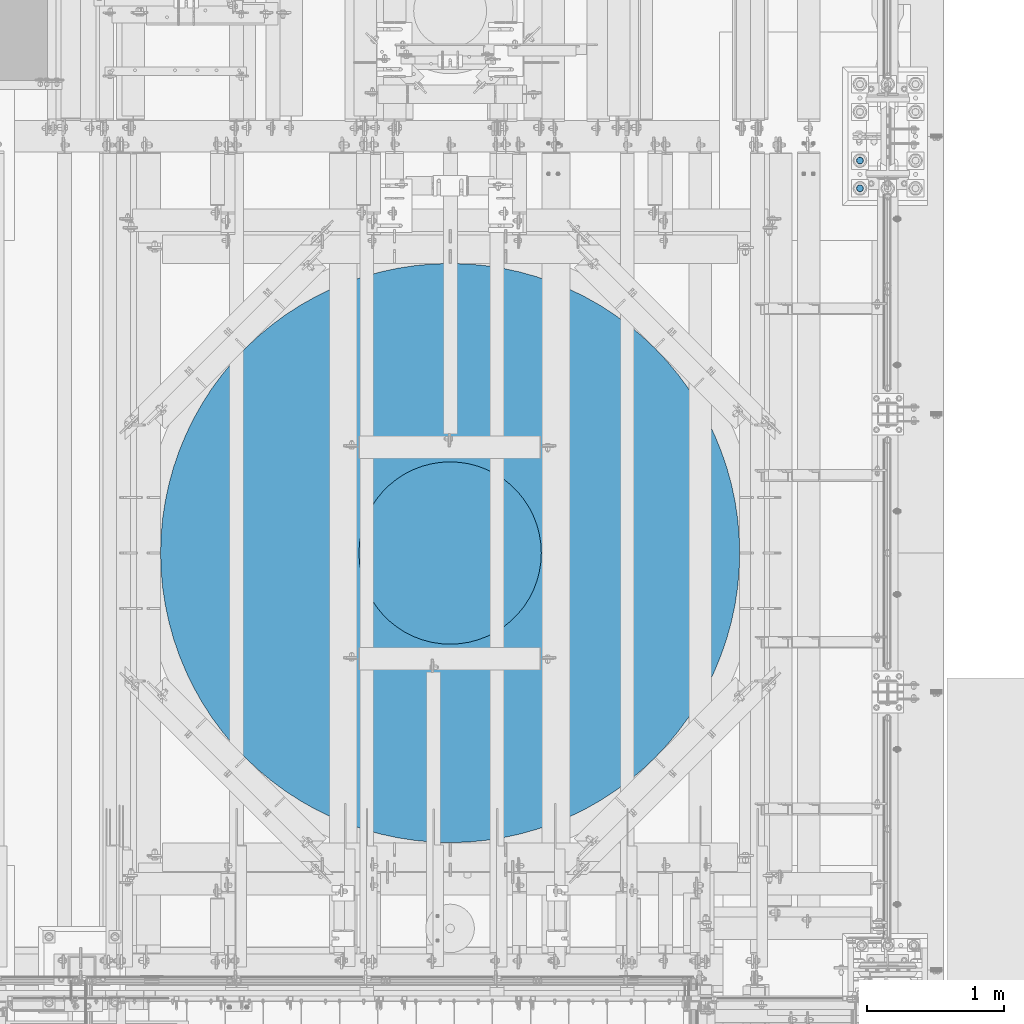
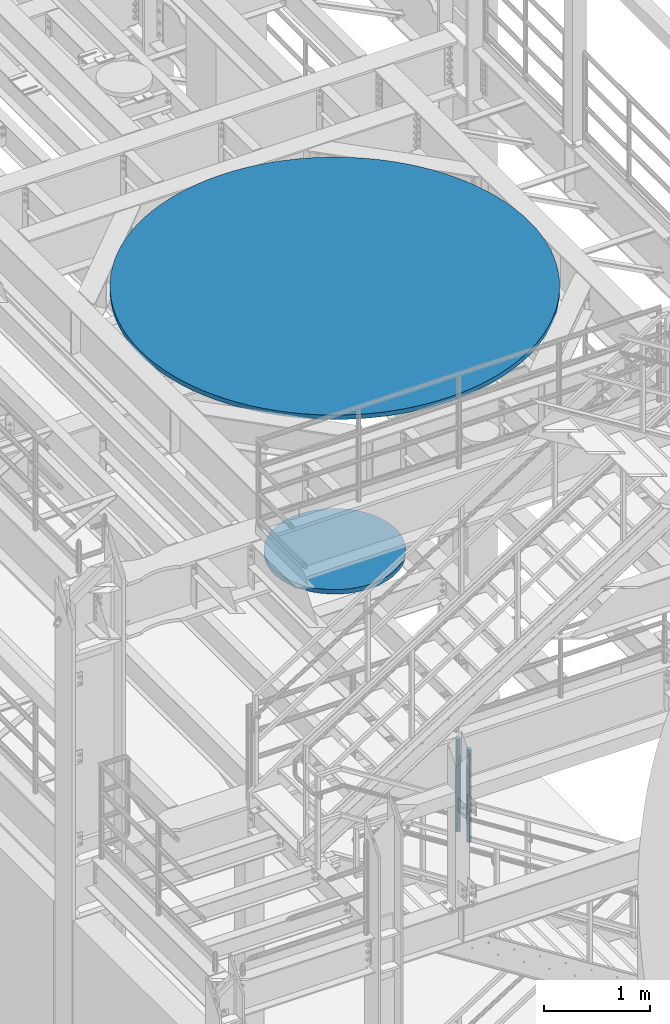
# One storey, part 690 of 1876: 4 columns, 3 elements without a shape of their own.
"""IFC2X3 building model written with IfcOpenShell, lengths in millimetres."""

from ifc_helpers import new_model, si_unit, frame, origin_with_axes, place, context, subcontext, project, spatial, faceted_brep, material, type_object, element, aggregate, save


model = new_model("IFC2X3")

# Units and contexts
model_context = context("Model", 3, precision=1e-05, world=origin_with_axes())
body_context = subcontext(model_context, "Body", "Model", "MODEL_VIEW")
ifc_project = project(units=[si_unit("LENGTHUNIT", "METRE", prefix="MILLI"), si_unit("AREAUNIT", "SQUARE_METRE"), si_unit("VOLUMEUNIT", "CUBIC_METRE"), si_unit("MASSUNIT", "GRAM", prefix="KILO"), si_unit("TIMEUNIT", "SECOND"), si_unit("PLANEANGLEUNIT", "RADIAN"), si_unit("SOLIDANGLEUNIT", "STERADIAN"), si_unit("THERMODYNAMICTEMPERATUREUNIT", "DEGREE_CELSIUS"), si_unit("LUMINOUSINTENSITYUNIT", "LUMEN")], contexts=[model_context])

# Site, building, storey
site_placement = place(None, origin_with_axes())
site = spatial("IfcSite", under=ifc_project, at=site_placement, CompositionType="ELEMENT")
building_placement = place(site_placement, origin_with_axes())
building = spatial("IfcBuilding", under=site, at=building_placement, Name="Undefined", CompositionType="ELEMENT")
storey_placement = place(building_placement, origin_with_axes())
storey = spatial("IfcBuildingStorey", under=building, at=storey_placement, Name="Undefined", CompositionType="ELEMENT", Elevation=0.0)

# Assembly, column
assembly_1_placement = place(storey_placement, origin_with_axes())
assembly_1 = element("IfcElementAssembly", 1, at=assembly_1_placement, inside=storey, Name="COLUMN", AssemblyPlace="NOTDEFINED", PredefinedType="REINFORCEMENT_UNIT")
ifc_material_1 = material(Name="CONCRETE/3000")
column_type_1 = type_object("IfcColumnType", PredefinedType="NOTDEFINED")
column_1_placement = place(assembly_1_placement, frame((4419.6, -1524.0, 8128.0), z_axis=(-1.0, 0.0, 0.0), x_axis=(0.0, 0.0, 1.0)))
column_1 = element("IfcColumn", 2, at=column_1_placement, type_object=column_type_1, material=ifc_material_1, Name="COLUMN", context=body_context, shape_type="Brep", body=[
    faceted_brep([(0.0, -2117.725, 0.0), (0.0, -2113.86132556757, -127.865053453613), (50.7999999999993, -2113.86132556757, -127.865053453613), (50.7999999999993, -2117.725, 0.0), (0.0, -2102.2844003993, -255.263541193705), (50.7999999999993, -2102.2844003993, -255.263541193705), (0.0, -2083.03646743964, -381.730599954454), (50.7999999999993, -2083.03646743964, -381.730599954454), (0.0, -2056.18776030859, -506.80476515337), (50.7999999999993, -2056.18776030859, -506.80476515337), (0.0, -2021.83624702681, -630.029654725511), (50.7999999999993, -2021.83624702681, -630.029654725511), (0.0, -1980.10727254097, -750.955634412155), (50.7999999999993, -1980.10727254097, -750.955634412155), (0.0, -1931.1531013536, -869.14145842744), (50.7999999999993, -1931.1531013536, -869.14145842744), (0.0, -1875.15236192644, -984.155879516391), (50.7999999999993, -1875.15236192644, -984.155879516391), (0.0, -1812.30939488458, -1095.57922252938), (50.7999999999993, -1812.30939488458, -1095.57922252938), (0.0, -1742.85350739964, -1203.00491577124), (50.7999999999993, -1742.85350739964, -1203.00491577124), (0.0, -1667.0381364728, -1306.04097453728), (50.7999999999993, -1667.0381364728, -1306.04097453728), (0.0, -1585.13992417064, -1404.31143142299), (50.7999999999993, -1585.13992417064, -1404.31143142299), (0.0, -1497.45770818828, -1497.45770818828), (50.7999999999993, -1497.45770818828, -1497.45770818828), (0.0, -1404.31143142299, -1585.13992417065), (50.7999999999993, -1404.31143142299, -1585.13992417065), (0.0, -1306.04097453728, -1667.0381364728), (50.7999999999993, -1306.04097453728, -1667.0381364728), (0.0, -1203.00491577124, -1742.85350739964), (50.7999999999993, -1203.00491577124, -1742.85350739964), (0.0, -1095.57922252938, -1812.30939488458), (50.7999999999993, -1095.57922252938, -1812.30939488458), (0.0, -984.155879516389, -1875.15236192644), (50.7999999999993, -984.155879516389, -1875.15236192644), (0.0, -869.141458427439, -1931.1531013536), (50.7999999999993, -869.141458427439, -1931.1531013536), (0.0, -750.955634412154, -1980.10727254097), (50.7999999999993, -750.955634412154, -1980.10727254097), (0.0, -630.029654725508, -2021.83624702681), (50.7999999999993, -630.029654725508, -2021.83624702681), (0.0, -506.804765153367, -2056.18776030859), (50.7999999999993, -506.804765153367, -2056.18776030859), (0.0, -381.730599954453, -2083.03646743964), (50.7999999999993, -381.730599954453, -2083.03646743964), (0.0, -255.263541193702, -2102.2844003993), (50.7999999999993, -255.263541193702, -2102.2844003993), (0.0, -127.86505345361, -2113.86132556758), (50.7999999999993, -127.86505345361, -2113.86132556758), (0.0, 4.54747350886464e-13, -2117.725), (50.7999999999993, 4.54747350886464e-13, -2117.725), (0.0, 127.865053453612, -2113.86132556757), (50.7999999999993, 127.865053453612, -2113.86132556757), (0.0, 255.263541193705, -2102.2844003993), (50.7999999999993, 255.263541193705, -2102.2844003993), (0.0, 381.730599954454, -2083.03646743964), (50.7999999999993, 381.730599954454, -2083.03646743964), (0.0, 506.804765153368, -2056.18776030859), (50.7999999999993, 506.804765153368, -2056.18776030859), (0.0, 630.029654725511, -2021.83624702681), (50.7999999999993, 630.029654725511, -2021.83624702681), (0.0, 750.955634412154, -1980.10727254097), (50.7999999999993, 750.955634412154, -1980.10727254097), (0.0, 869.141458427439, -1931.1531013536), (50.7999999999993, 869.141458427439, -1931.1531013536), (0.0, 984.155879516391, -1875.15236192644), (50.7999999999993, 984.155879516391, -1875.15236192644), (0.0, 1095.57922252938, -1812.30939488458), (50.7999999999993, 1095.57922252938, -1812.30939488458), (0.0, 1203.00491577124, -1742.85350739964), (50.7999999999993, 1203.00491577124, -1742.85350739964), (0.0, 1306.04097453728, -1667.0381364728), (50.7999999999993, 1306.04097453728, -1667.0381364728), (0.0, 1404.31143142299, -1585.13992417064), (50.7999999999993, 1404.31143142299, -1585.13992417064), (0.0, 1497.45770818828, -1497.45770818828), (50.7999999999993, 1497.45770818828, -1497.45770818828), (0.0, 1585.13992417065, -1404.31143142299), (50.7999999999993, 1585.13992417065, -1404.31143142299), (0.0, 1667.0381364728, -1306.04097453728), (50.7999999999993, 1667.0381364728, -1306.04097453728), (0.0, 1742.85350739964, -1203.00491577124), (50.7999999999993, 1742.85350739964, -1203.00491577124), (0.0, 1812.30939488458, -1095.57922252938), (50.7999999999993, 1812.30939488458, -1095.57922252938), (0.0, 1875.15236192644, -984.155879516389), (50.7999999999993, 1875.15236192644, -984.155879516389), (0.0, 1931.1531013536, -869.141458427439), (50.7999999999993, 1931.1531013536, -869.141458427439), (0.0, 1980.10727254097, -750.955634412153), (50.7999999999993, 1980.10727254097, -750.955634412153), (0.0, 2021.83624702681, -630.029654725509), (50.7999999999993, 2021.83624702681, -630.029654725509), (0.0, 2056.18776030859, -506.804765153368), (50.7999999999993, 2056.18776030859, -506.804765153368), (0.0, 2083.03646743964, -381.730599954453), (50.7999999999993, 2083.03646743964, -381.730599954453), (0.0, 2102.2844003993, -255.263541193704), (50.7999999999993, 2102.2844003993, -255.263541193704), (0.0, 2113.86132556758, -127.86505345361), (50.7999999999993, 2113.86132556758, -127.86505345361), (0.0, 2117.725, 0.0), (50.7999999999993, 2117.725, 0.0), (0.0, 2113.86132556758, 127.865053453611), (50.7999999999993, 2113.86132556758, 127.865053453611), (0.0, 2102.2844003993, 255.263541193705), (50.7999999999993, 2102.2844003993, 255.263541193705), (0.0, 2083.03646743964, 381.730599954454), (50.7999999999993, 2083.03646743964, 381.730599954454), (0.0, 2056.18776030859, 506.804765153369), (50.7999999999993, 2056.18776030859, 506.804765153369), (0.0, 2021.83624702681, 630.02965472551), (50.7999999999993, 2021.83624702681, 630.02965472551), (0.0, 1980.10727254097, 750.955634412154), (50.7999999999993, 1980.10727254097, 750.955634412154), (0.0, 1931.1531013536, 869.14145842744), (50.7999999999993, 1931.1531013536, 869.14145842744), (0.0, 1875.15236192644, 984.15587951639), (50.7999999999993, 1875.15236192644, 984.15587951639), (0.0, 1812.30939488458, 1095.57922252938), (50.7999999999993, 1812.30939488458, 1095.57922252938), (0.0, 1742.85350739964, 1203.00491577124), (50.7999999999993, 1742.85350739964, 1203.00491577124), (0.0, 1667.0381364728, 1306.04097453728), (50.7999999999993, 1667.0381364728, 1306.04097453728), (0.0, 1585.13992417064, 1404.31143142299), (50.7999999999993, 1585.13992417064, 1404.31143142299), (0.0, 1497.45770818828, 1497.45770818828), (50.7999999999993, 1497.45770818828, 1497.45770818828), (0.0, 1404.31143142299, 1585.13992417065), (50.7999999999993, 1404.31143142299, 1585.13992417065), (0.0, 1306.04097453728, 1667.0381364728), (50.7999999999993, 1306.04097453728, 1667.0381364728), (0.0, 1203.00491577124, 1742.85350739964), (50.7999999999993, 1203.00491577124, 1742.85350739964), (0.0, 1095.57922252938, 1812.30939488458), (50.7999999999993, 1095.57922252938, 1812.30939488458), (0.0, 984.15587951639, 1875.15236192644), (50.7999999999993, 984.15587951639, 1875.15236192644), (0.0, 869.141458427439, 1931.1531013536), (50.7999999999993, 869.141458427439, 1931.1531013536), (0.0, 750.955634412153, 1980.10727254097), (50.7999999999993, 750.955634412153, 1980.10727254097), (0.0, 630.029654725509, 2021.83624702681), (50.7999999999993, 630.029654725509, 2021.83624702681), (0.0, 506.804765153368, 2056.18776030859), (50.7999999999993, 506.804765153368, 2056.18776030859), (0.0, 381.730599954453, 2083.03646743964), (50.7999999999993, 381.730599954453, 2083.03646743964), (0.0, 255.263541193704, 2102.2844003993), (50.7999999999993, 255.263541193704, 2102.2844003993), (0.0, 127.86505345361, 2113.86132556758), (50.7999999999993, 127.86505345361, 2113.86132556758), (0.0, -2.27373675443232e-13, 2117.725), (50.7999999999993, -2.27373675443232e-13, 2117.725), (0.0, -127.865053453611, 2113.86132556758), (50.7999999999993, -127.865053453611, 2113.86132556758), (0.0, -255.263541193704, 2102.2844003993), (50.7999999999993, -255.263541193704, 2102.2844003993), (0.0, -381.730599954454, 2083.03646743964), (50.7999999999993, -381.730599954454, 2083.03646743964), (0.0, -506.804765153368, 2056.18776030859), (50.7999999999993, -506.804765153368, 2056.18776030859), (0.0, -630.02965472551, 2021.83624702681), (50.7999999999993, -630.02965472551, 2021.83624702681), (0.0, -750.955634412154, 1980.10727254097), (50.7999999999993, -750.955634412154, 1980.10727254097), (0.0, -869.14145842744, 1931.1531013536), (50.7999999999993, -869.14145842744, 1931.1531013536), (0.0, -984.15587951639, 1875.15236192644), (50.7999999999993, -984.15587951639, 1875.15236192644), (0.0, -1095.57922252938, 1812.30939488458), (50.7999999999993, -1095.57922252938, 1812.30939488458), (0.0, -1203.00491577124, 1742.85350739964), (50.7999999999993, -1203.00491577124, 1742.85350739964), (0.0, -1306.04097453728, 1667.0381364728), (50.7999999999993, -1306.04097453728, 1667.0381364728), (0.0, -1404.31143142299, 1585.13992417064), (50.7999999999993, -1404.31143142299, 1585.13992417064), (0.0, -1497.45770818828, 1497.45770818828), (50.7999999999993, -1497.45770818828, 1497.45770818828), (0.0, -1585.13992417064, 1404.31143142299), (50.7999999999993, -1585.13992417064, 1404.31143142299), (0.0, -1667.0381364728, 1306.04097453728), (50.7999999999993, -1667.0381364728, 1306.04097453728), (0.0, -1742.85350739964, 1203.00491577124), (50.7999999999993, -1742.85350739964, 1203.00491577124), (0.0, -1812.30939488458, 1095.57922252938), (50.7999999999993, -1812.30939488458, 1095.57922252938), (0.0, -1875.15236192644, 984.15587951639), (50.7999999999993, -1875.15236192644, 984.15587951639), (0.0, -1931.1531013536, 869.141458427439), (50.7999999999993, -1931.1531013536, 869.141458427439), (0.0, -1980.10727254097, 750.955634412154), (50.7999999999993, -1980.10727254097, 750.955634412154), (0.0, -2021.83624702681, 630.029654725509), (50.7999999999993, -2021.83624702681, 630.029654725509), (0.0, -2056.18776030859, 506.804765153368), (50.7999999999993, -2056.18776030859, 506.804765153368), (0.0, -2083.03646743964, 381.730599954453), (50.7999999999993, -2083.03646743964, 381.730599954453), (0.0, -2102.2844003993, 255.263541193704), (50.7999999999993, -2102.2844003993, 255.263541193704), (0.0, -2113.86132556758, 127.865053453611), (50.7999999999993, -2113.86132556758, 127.865053453611)], [[[0, 1, 2, 3]], [[1, 4, 5, 2]], [[4, 6, 7, 5]], [[6, 8, 9, 7]], [[8, 10, 11, 9]], [[10, 12, 13, 11]], [[12, 14, 15, 13]], [[14, 16, 17, 15]], [[16, 18, 19, 17]], [[18, 20, 21, 19]], [[20, 22, 23, 21]], [[22, 24, 25, 23]], [[24, 26, 27, 25]], [[26, 28, 29, 27]], [[28, 30, 31, 29]], [[30, 32, 33, 31]], [[32, 34, 35, 33]], [[34, 36, 37, 35]], [[36, 38, 39, 37]], [[38, 40, 41, 39]], [[40, 42, 43, 41]], [[42, 44, 45, 43]], [[44, 46, 47, 45]], [[46, 48, 49, 47]], [[48, 50, 51, 49]], [[50, 52, 53, 51]], [[52, 54, 55, 53]], [[54, 56, 57, 55]], [[56, 58, 59, 57]], [[58, 60, 61, 59]], [[60, 62, 63, 61]], [[62, 64, 65, 63]], [[64, 66, 67, 65]], [[66, 68, 69, 67]], [[68, 70, 71, 69]], [[70, 72, 73, 71]], [[72, 74, 75, 73]], [[74, 76, 77, 75]], [[76, 78, 79, 77]], [[78, 80, 81, 79]], [[80, 82, 83, 81]], [[82, 84, 85, 83]], [[84, 86, 87, 85]], [[86, 88, 89, 87]], [[88, 90, 91, 89]], [[90, 92, 93, 91]], [[92, 94, 95, 93]], [[94, 96, 97, 95]], [[96, 98, 99, 97]], [[98, 100, 101, 99]], [[100, 102, 103, 101]], [[102, 104, 105, 103]], [[104, 106, 107, 105]], [[106, 108, 109, 107]], [[108, 110, 111, 109]], [[110, 112, 113, 111]], [[112, 114, 115, 113]], [[114, 116, 117, 115]], [[116, 118, 119, 117]], [[118, 120, 121, 119]], [[120, 122, 123, 121]], [[122, 124, 125, 123]], [[124, 126, 127, 125]], [[126, 128, 129, 127]], [[128, 130, 131, 129]], [[130, 132, 133, 131]], [[132, 134, 135, 133]], [[134, 136, 137, 135]], [[136, 138, 139, 137]], [[138, 140, 141, 139]], [[140, 142, 143, 141]], [[142, 144, 145, 143]], [[144, 146, 147, 145]], [[146, 148, 149, 147]], [[148, 150, 151, 149]], [[150, 152, 153, 151]], [[152, 154, 155, 153]], [[154, 156, 157, 155]], [[156, 158, 159, 157]], [[158, 160, 161, 159]], [[160, 162, 163, 161]], [[162, 164, 165, 163]], [[164, 166, 167, 165]], [[166, 168, 169, 167]], [[168, 170, 171, 169]], [[170, 172, 173, 171]], [[172, 174, 175, 173]], [[174, 176, 177, 175]], [[176, 178, 179, 177]], [[178, 180, 181, 179]], [[180, 182, 183, 181]], [[182, 184, 185, 183]], [[184, 186, 187, 185]], [[186, 188, 189, 187]], [[188, 190, 191, 189]], [[190, 192, 193, 191]], [[192, 194, 195, 193]], [[194, 196, 197, 195]], [[196, 198, 199, 197]], [[198, 200, 201, 199]], [[200, 202, 203, 201]], [[202, 204, 205, 203]], [[204, 206, 207, 205]], [[206, 0, 3, 207]], [[5, 7, 9, 11, 13, 15, 17, 19, 21, 23, 25, 27, 29, 31, 33, 35, 37, 39, 41, 43, 45, 47, 49, 51, 53, 55, 57, 59, 61, 63, 65, 67, 69, 71, 73, 75, 77, 79, 81, 83, 85, 87, 89, 91, 93, 95, 97, 99, 101, 103, 105, 107, 109, 111, 113, 115, 117, 119, 121, 123, 125, 127, 129, 131, 133, 135, 137, 139, 141, 143, 145, 147, 149, 151, 153, 155, 157, 159, 161, 163, 165, 167, 169, 171, 173, 175, 177, 179, 181, 183, 185, 187, 189, 191, 193, 195, 197, 199, 201, 203, 205, 207, 3, 2]], [[206, 204, 202, 200, 198, 196, 194, 192, 190, 188, 186, 184, 182, 180, 178, 176, 174, 172, 170, 168, 166, 164, 162, 160, 158, 156, 154, 152, 150, 148, 146, 144, 142, 140, 138, 136, 134, 132, 130, 128, 126, 124, 122, 120, 118, 116, 114, 112, 110, 108, 106, 104, 102, 100, 98, 96, 94, 92, 90, 88, 86, 84, 82, 80, 78, 76, 74, 72, 70, 68, 66, 64, 62, 60, 58, 56, 54, 52, 50, 48, 46, 44, 42, 40, 38, 36, 34, 32, 30, 28, 26, 24, 22, 20, 18, 16, 14, 12, 10, 8, 6, 4, 1, 0]]]),
])
aggregate(assembly_1, [column_1])

assembly_2_placement = place(storey_placement, origin_with_axes())
assembly_2 = element("IfcElementAssembly", 3, at=assembly_2_placement, inside=storey, Name="COLUMN", AssemblyPlace="NOTDEFINED", PredefinedType="REINFORCEMENT_UNIT")
column_type_2 = type_object("IfcColumnType", PredefinedType="NOTDEFINED")
column_2_placement = place(assembly_2_placement, frame((4419.6, -1524.0, 5105.4), z_axis=(-1.0, 0.0, 0.0), x_axis=(0.0, 0.0, 1.0)))
column_2 = element("IfcColumn", 4, at=column_2_placement, type_object=column_type_2, material=ifc_material_1, Name="COLUMN", context=body_context, shape_type="Brep", body=[
    faceted_brep([(0.0, -666.75, 0.0), (0.0, -663.097473736796, -69.6943528837082), (50.7999999999993, -663.097473736796, -69.6943528837082), (50.7999999999993, -666.75, 0.0), (0.0, -652.179912789265, -138.625119852742), (50.7999999999993, -652.179912789265, -138.625119852742), (0.0, -634.116932239794, -206.037080999497), (50.7999999999993, -634.116932239794, -206.037080999497), (0.0, -609.106433883204, -271.19165677079), (50.7999999999993, -609.106433883204, -271.19165677079), (0.0, -577.422437973274, -333.375), (50.7999999999993, -577.422437973274, -333.375), (0.0, -539.412080999496, -391.905816966007), (50.7999999999993, -539.412080999496, -391.905816966007), (0.0, -495.491812387052, -446.142831789769), (50.7999999999993, -495.491812387052, -446.142831789769), (0.0, -446.142831789768, -495.491812387053), (50.7999999999993, -446.142831789768, -495.491812387053), (0.0, -391.905816966006, -539.412080999497), (50.7999999999993, -391.905816966006, -539.412080999497), (0.0, -333.375, -577.422437973275), (50.7999999999993, -333.375, -577.422437973275), (0.0, -271.191656770789, -609.106433883204), (50.7999999999993, -271.191656770789, -609.106433883204), (0.0, -206.037080999496, -634.116932239794), (50.7999999999993, -206.037080999496, -634.116932239794), (0.0, -138.62511985274, -652.179912789265), (50.7999999999993, -138.62511985274, -652.179912789265), (0.0, -69.6943528837076, -663.097473736796), (50.7999999999993, -69.6943528837076, -663.097473736796), (0.0, 2.27373675443232e-13, -666.75), (50.7999999999993, 2.27373675443232e-13, -666.75), (0.0, 69.6943528837085, -663.097473736796), (50.7999999999993, 69.6943528837085, -663.097473736796), (0.0, 138.625119852741, -652.179912789265), (50.7999999999993, 138.625119852741, -652.179912789265), (0.0, 206.037080999496, -634.116932239794), (50.7999999999993, 206.037080999496, -634.116932239794), (0.0, 271.19165677079, -609.106433883204), (50.7999999999993, 271.19165677079, -609.106433883204), (0.0, 333.375, -577.422437973274), (50.7999999999993, 333.375, -577.422437973274), (0.0, 391.905816966007, -539.412080999497), (50.7999999999993, 391.905816966007, -539.412080999497), (0.0, 446.142831789769, -495.491812387052), (50.7999999999993, 446.142831789769, -495.491812387052), (0.0, 495.491812387053, -446.142831789769), (50.7999999999993, 495.491812387053, -446.142831789769), (0.0, 539.412080999496, -391.905816966007), (50.7999999999993, 539.412080999496, -391.905816966007), (0.0, 577.422437973275, -333.375), (50.7999999999993, 577.422437973275, -333.375), (0.0, 609.106433883204, -271.191656770789), (50.7999999999993, 609.106433883204, -271.191656770789), (0.0, 634.116932239794, -206.037080999497), (50.7999999999993, 634.116932239794, -206.037080999497), (0.0, 652.179912789265, -138.625119852741), (50.7999999999993, 652.179912789265, -138.625119852741), (0.0, 663.097473736796, -69.6943528837073), (50.7999999999993, 663.097473736796, -69.6943528837073), (0.0, 666.75, 0.0), (50.7999999999993, 666.75, 0.0), (0.0, 663.097473736796, 69.6943528837082), (50.7999999999993, 663.097473736796, 69.6943528837082), (0.0, 652.179912789265, 138.625119852742), (50.7999999999993, 652.179912789265, 138.625119852742), (0.0, 634.116932239794, 206.037080999497), (50.7999999999993, 634.116932239794, 206.037080999497), (0.0, 609.106433883204, 271.19165677079), (50.7999999999993, 609.106433883204, 271.19165677079), (0.0, 577.422437973274, 333.375), (50.7999999999993, 577.422437973274, 333.375), (0.0, 539.412080999496, 391.905816966007), (50.7999999999993, 539.412080999496, 391.905816966007), (0.0, 495.491812387053, 446.142831789769), (50.7999999999993, 495.491812387053, 446.142831789769), (0.0, 446.142831789768, 495.491812387053), (50.7999999999993, 446.142831789768, 495.491812387053), (0.0, 391.905816966006, 539.412080999496), (50.7999999999993, 391.905816966006, 539.412080999496), (0.0, 333.375, 577.422437973275), (50.7999999999993, 333.375, 577.422437973275), (0.0, 271.19165677079, 609.106433883204), (50.7999999999993, 271.19165677079, 609.106433883204), (0.0, 206.037080999496, 634.116932239794), (50.7999999999993, 206.037080999496, 634.116932239794), (0.0, 138.625119852741, 652.179912789265), (50.7999999999993, 138.625119852741, 652.179912789265), (0.0, 69.6943528837078, 663.097473736796), (50.7999999999993, 69.6943528837078, 663.097473736796), (0.0, 0.0, 666.75), (50.7999999999993, 0.0, 666.75), (0.0, -69.694352883708, 663.097473736796), (50.7999999999993, -69.694352883708, 663.097473736796), (0.0, -138.625119852741, 652.179912789265), (50.7999999999993, -138.625119852741, 652.179912789265), (0.0, -206.037080999496, 634.116932239794), (50.7999999999993, -206.037080999496, 634.116932239794), (0.0, -271.19165677079, 609.106433883204), (50.7999999999993, -271.19165677079, 609.106433883204), (0.0, -333.375, 577.422437973275), (50.7999999999993, -333.375, 577.422437973275), (0.0, -391.905816966007, 539.412080999496), (50.7999999999993, -391.905816966007, 539.412080999496), (0.0, -446.142831789769, 495.491812387053), (50.7999999999993, -446.142831789769, 495.491812387053), (0.0, -495.491812387053, 446.142831789768), (50.7999999999993, -495.491812387053, 446.142831789768), (0.0, -539.412080999496, 391.905816966007), (50.7999999999993, -539.412080999496, 391.905816966007), (0.0, -577.422437973275, 333.375), (50.7999999999993, -577.422437973275, 333.375), (0.0, -609.106433883204, 271.191656770789), (50.7999999999993, -609.106433883204, 271.191656770789), (0.0, -634.116932239794, 206.037080999497), (50.7999999999993, -634.116932239794, 206.037080999497), (0.0, -652.179912789265, 138.625119852741), (50.7999999999993, -652.179912789265, 138.625119852741), (0.0, -663.097473736796, 69.6943528837082), (50.7999999999993, -663.097473736796, 69.6943528837082)], [[[0, 1, 2, 3]], [[1, 4, 5, 2]], [[4, 6, 7, 5]], [[6, 8, 9, 7]], [[8, 10, 11, 9]], [[10, 12, 13, 11]], [[12, 14, 15, 13]], [[14, 16, 17, 15]], [[16, 18, 19, 17]], [[18, 20, 21, 19]], [[20, 22, 23, 21]], [[22, 24, 25, 23]], [[24, 26, 27, 25]], [[26, 28, 29, 27]], [[28, 30, 31, 29]], [[30, 32, 33, 31]], [[32, 34, 35, 33]], [[34, 36, 37, 35]], [[36, 38, 39, 37]], [[38, 40, 41, 39]], [[40, 42, 43, 41]], [[42, 44, 45, 43]], [[44, 46, 47, 45]], [[46, 48, 49, 47]], [[48, 50, 51, 49]], [[50, 52, 53, 51]], [[52, 54, 55, 53]], [[54, 56, 57, 55]], [[56, 58, 59, 57]], [[58, 60, 61, 59]], [[60, 62, 63, 61]], [[62, 64, 65, 63]], [[64, 66, 67, 65]], [[66, 68, 69, 67]], [[68, 70, 71, 69]], [[70, 72, 73, 71]], [[72, 74, 75, 73]], [[74, 76, 77, 75]], [[76, 78, 79, 77]], [[78, 80, 81, 79]], [[80, 82, 83, 81]], [[82, 84, 85, 83]], [[84, 86, 87, 85]], [[86, 88, 89, 87]], [[88, 90, 91, 89]], [[90, 92, 93, 91]], [[92, 94, 95, 93]], [[94, 96, 97, 95]], [[96, 98, 99, 97]], [[98, 100, 101, 99]], [[100, 102, 103, 101]], [[102, 104, 105, 103]], [[104, 106, 107, 105]], [[106, 108, 109, 107]], [[108, 110, 111, 109]], [[110, 112, 113, 111]], [[112, 114, 115, 113]], [[114, 116, 117, 115]], [[116, 118, 119, 117]], [[118, 0, 3, 119]], [[5, 7, 9, 11, 13, 15, 17, 19, 21, 23, 25, 27, 29, 31, 33, 35, 37, 39, 41, 43, 45, 47, 49, 51, 53, 55, 57, 59, 61, 63, 65, 67, 69, 71, 73, 75, 77, 79, 81, 83, 85, 87, 89, 91, 93, 95, 97, 99, 101, 103, 105, 107, 109, 111, 113, 115, 117, 119, 3, 2]], [[118, 116, 114, 112, 110, 108, 106, 104, 102, 100, 98, 96, 94, 92, 90, 88, 86, 84, 82, 80, 78, 76, 74, 72, 70, 68, 66, 64, 62, 60, 58, 56, 54, 52, 50, 48, 46, 44, 42, 40, 38, 36, 34, 32, 30, 28, 26, 24, 22, 20, 18, 16, 14, 12, 10, 8, 6, 4, 1, 0]]]),
])
aggregate(assembly_2, [column_2])

# Assembly, columns
assembly_3_placement = place(storey_placement, origin_with_axes())
assembly_3 = element("IfcElementAssembly", 5, at=assembly_3_placement, inside=storey, Name="TEMPLATE", AssemblyPlace="NOTDEFINED", PredefinedType="RIGID_FRAME")
ifc_material_2 = material(Name="STEEL/F1554-GR.105")
column_type_3 = type_object("IfcColumnType", PredefinedType="NOTDEFINED")
column_3_placement = place(assembly_3_placement, frame((7416.8, 1143.0, 0.0), z_axis=(0.0, -1.0, 0.0), x_axis=(0.0, 0.0, -1.0)))
column_3 = element("IfcColumn", 6, at=column_3_placement, type_object=column_type_3, material=ifc_material_2, Name="ANCHOR_BOLTS", context=body_context, shape_type="Brep", body=[
    faceted_brep([(-196.85, -21.217622392719, 12.25), (-196.85, -12.25, 21.2176223927188), (-196.85, 0.0, 24.5), (-196.85, 12.25, 21.2176223927188), (-196.85, 21.217622392719, 12.25), (-196.85, 24.5, 0.0), (-196.85, 21.217622392719, -12.25), (-196.85, 12.25, -21.2176223927188), (-196.85, 0.0, -24.5), (-196.85, -12.25, -21.2176223927188), (-196.85, -21.217622392719, -12.25), (-196.85, -24.5, 0.0), (0.0, 24.5, 0.0), (0.0, 21.217622392719, -12.25), (0.0, 12.25, -21.2176223927188), (0.0, 0.0, -24.5), (0.0, -12.25, -21.2176223927188), (0.0, -21.217622392719, -12.25), (0.0, -24.5, 0.0), (0.0, -21.217622392719, 12.25), (0.0, -12.25, 21.2176223927188), (0.0, 0.0, 24.5), (0.0, 12.25, 21.2176223927188), (0.0, 21.217622392719, 12.25), (0.0, -23.4665401257871, 9.7201591820733), (0.0, -17.9605122421381, 17.9605122421383), (0.0, -9.72015918207308, 23.4665401257867), (0.0, 0.0, 25.4000000000001), (0.0, 9.72015918207308, 23.4665401257867), (0.0, 17.9605122421381, 17.9605122421383), (0.0, 23.4665401257871, 9.7201591820733), (0.0, 25.3999996185339, 9.09494701772928e-13), (0.0, 23.4665401257871, -9.7201591820733), (0.0, 17.9605122421381, -17.9605122421383), (0.0, 9.72015918207308, -23.4665401257867), (0.0, 0.0, -25.4000000000001), (0.0, -9.72015918207308, -23.4665401257867), (0.0, -17.9605122421381, -17.9605122421383), (0.0, -23.4665401257871, -9.7201591820733), (0.0, -25.3999996185375, 0.0), (673.1, -25.3999999999996, 0.0), (673.1, -23.4665401257871, 9.7201591820733), (673.1, -17.9605122421381, 17.9605122421383), (673.1, -9.72015918207308, 23.4665401257867), (673.1, 0.0, 25.4000000000001), (673.1, 9.72015918207308, 23.4665401257867), (673.1, 17.9605122421381, 17.9605122421383), (673.1, 23.4665401257871, 9.7201591820733), (673.1, 25.3999999999996, 0.0), (673.1, 23.4665401257871, -9.7201591820733), (673.1, 17.9605122421381, -17.9605122421383), (673.1, 9.72015918207308, -23.4665401257867), (673.1, 0.0, -25.4000000000001), (673.1, -9.72015918207308, -23.4665401257867), (673.1, -17.9605122421381, -17.9605122421383), (673.1, -23.4665401257871, -9.7201591820733), (673.1, -12.25, 21.2176223927188), (673.1, 0.0, 24.5), (673.1, 12.25, 21.2176223927188), (673.1, 21.217622392719, 12.25), (673.1, 24.5, 0.0), (673.1, 21.217622392719, -12.25), (673.1, 12.25, -21.2176223927188), (673.1, 0.0, -24.5), (673.1, -12.25, -21.2176223927188), (673.1, -21.217622392719, -12.25), (673.1, -24.5, 0.0), (673.1, -21.217622392719, 12.25), (869.95, -12.25, -21.2176223927188), (869.95, 0.0, -24.5), (869.95, 12.25, -21.2176223927188), (869.95, 21.217622392719, -12.25), (869.95, 24.5, 0.0), (869.95, 21.217622392719, 12.25), (869.95, 12.25, 21.2176223927188), (869.95, 0.0, 24.5), (869.95, -12.25, 21.2176223927188), (869.95, -21.217622392719, 12.25), (869.95, -24.5, 0.0), (869.95, -21.217622392719, -12.25)], [[[0, 1, 2, 3, 4, 5, 6, 7, 8, 9, 10, 11]], [[6, 5, 12, 13]], [[7, 6, 13, 14]], [[8, 7, 14, 15]], [[9, 8, 15, 16]], [[10, 9, 16, 17]], [[11, 10, 17, 18]], [[0, 11, 18, 19]], [[1, 0, 19, 20]], [[2, 1, 20, 21]], [[3, 2, 21, 22]], [[4, 3, 22, 23]], [[5, 4, 23, 12]], [[24, 25, 26, 27, 28, 29, 30, 31, 32, 33, 34, 35, 36, 37, 38, 39], [22, 21, 20, 19, 18, 17, 16, 15, 14, 13, 12, 23]], [[24, 39, 40, 41]], [[25, 24, 41, 42]], [[26, 25, 42, 43]], [[27, 26, 43, 44]], [[28, 27, 44, 45]], [[29, 28, 45, 46]], [[30, 29, 46, 47]], [[31, 30, 47, 48]], [[32, 31, 48, 49]], [[33, 32, 49, 50]], [[34, 33, 50, 51]], [[35, 34, 51, 52]], [[36, 35, 52, 53]], [[37, 36, 53, 54]], [[38, 37, 54, 55]], [[39, 38, 55, 40]], [[54, 53, 52, 51, 50, 49, 48, 47, 46, 45, 44, 43, 42, 41, 40, 55], [56, 57, 58, 59, 60, 61, 62, 63, 64, 65, 66, 67]], [[68, 69, 70, 71, 72, 73, 74, 75, 76, 77, 78, 79]], [[76, 75, 57, 56]], [[77, 76, 56, 67]], [[78, 77, 67, 66]], [[79, 78, 66, 65]], [[68, 79, 65, 64]], [[69, 68, 64, 63]], [[70, 69, 63, 62]], [[71, 70, 62, 61]], [[72, 71, 61, 60]], [[73, 72, 60, 59]], [[74, 73, 59, 58]], [[75, 74, 58, 57]]]),
])
column_4_placement = place(assembly_3_placement, frame((7416.8, 1346.2, 0.0), z_axis=(0.0, -1.0, 0.0), x_axis=(0.0, 0.0, -1.0)))
column_4 = element("IfcColumn", 7, at=column_4_placement, type_object=column_type_3, material=ifc_material_2, Name="ANCHOR_BOLTS", context=body_context, shape_type="Brep", body=[
    faceted_brep([(-196.85, -21.217622392719, 12.25), (-196.85, -12.25, 21.2176223927188), (-196.85, 0.0, 24.5), (-196.85, 12.25, 21.2176223927188), (-196.85, 21.217622392719, 12.25), (-196.85, 24.5, 0.0), (-196.85, 21.217622392719, -12.25), (-196.85, 12.25, -21.2176223927188), (-196.85, 0.0, -24.5), (-196.85, -12.25, -21.2176223927188), (-196.85, -21.217622392719, -12.25), (-196.85, -24.5, 0.0), (0.0, 24.5, 0.0), (0.0, 21.217622392719, -12.25), (0.0, 12.25, -21.2176223927188), (0.0, 0.0, -24.5), (0.0, -12.25, -21.2176223927188), (0.0, -21.217622392719, -12.25), (0.0, -24.5, 0.0), (0.0, -21.217622392719, 12.25), (0.0, -12.25, 21.2176223927188), (0.0, 0.0, 24.5), (0.0, 12.25, 21.2176223927188), (0.0, 21.217622392719, 12.25), (0.0, -23.4665401257871, 9.7201591820733), (0.0, -17.9605122421381, 17.9605122421383), (0.0, -9.72015918207308, 23.4665401257867), (0.0, 0.0, 25.4000000000001), (0.0, 9.72015918207308, 23.4665401257867), (0.0, 17.9605122421381, 17.9605122421383), (0.0, 23.4665401257871, 9.7201591820733), (0.0, 25.3999996185339, 9.09494701772928e-13), (0.0, 23.4665401257871, -9.7201591820733), (0.0, 17.9605122421381, -17.9605122421383), (0.0, 9.72015918207308, -23.4665401257867), (0.0, 0.0, -25.4000000000001), (0.0, -9.72015918207308, -23.4665401257867), (0.0, -17.9605122421381, -17.9605122421383), (0.0, -23.4665401257871, -9.7201591820733), (0.0, -25.3999996185375, 0.0), (673.1, -25.3999999999996, 0.0), (673.1, -23.4665401257871, 9.7201591820733), (673.1, -17.9605122421381, 17.9605122421383), (673.1, -9.72015918207308, 23.4665401257867), (673.1, 0.0, 25.4000000000001), (673.1, 9.72015918207308, 23.4665401257867), (673.1, 17.9605122421381, 17.9605122421383), (673.1, 23.4665401257871, 9.7201591820733), (673.1, 25.3999999999996, 0.0), (673.1, 23.4665401257871, -9.7201591820733), (673.1, 17.9605122421381, -17.9605122421383), (673.1, 9.72015918207308, -23.4665401257867), (673.1, 0.0, -25.4000000000001), (673.1, -9.72015918207308, -23.4665401257867), (673.1, -17.9605122421381, -17.9605122421383), (673.1, -23.4665401257871, -9.7201591820733), (673.1, -12.25, 21.2176223927188), (673.1, 0.0, 24.5), (673.1, 12.25, 21.2176223927188), (673.1, 21.217622392719, 12.25), (673.1, 24.5, 0.0), (673.1, 21.217622392719, -12.25), (673.1, 12.25, -21.2176223927188), (673.1, 0.0, -24.5), (673.1, -12.25, -21.2176223927188), (673.1, -21.217622392719, -12.25), (673.1, -24.5, 0.0), (673.1, -21.217622392719, 12.25), (869.95, -12.25, -21.2176223927188), (869.95, 0.0, -24.5), (869.95, 12.25, -21.2176223927188), (869.95, 21.217622392719, -12.25), (869.95, 24.5, 0.0), (869.95, 21.217622392719, 12.25), (869.95, 12.25, 21.2176223927188), (869.95, 0.0, 24.5), (869.95, -12.25, 21.2176223927188), (869.95, -21.217622392719, 12.25), (869.95, -24.5, 0.0), (869.95, -21.217622392719, -12.25)], [[[0, 1, 2, 3, 4, 5, 6, 7, 8, 9, 10, 11]], [[6, 5, 12, 13]], [[7, 6, 13, 14]], [[8, 7, 14, 15]], [[9, 8, 15, 16]], [[10, 9, 16, 17]], [[11, 10, 17, 18]], [[0, 11, 18, 19]], [[1, 0, 19, 20]], [[2, 1, 20, 21]], [[3, 2, 21, 22]], [[4, 3, 22, 23]], [[5, 4, 23, 12]], [[24, 25, 26, 27, 28, 29, 30, 31, 32, 33, 34, 35, 36, 37, 38, 39], [22, 21, 20, 19, 18, 17, 16, 15, 14, 13, 12, 23]], [[24, 39, 40, 41]], [[25, 24, 41, 42]], [[26, 25, 42, 43]], [[27, 26, 43, 44]], [[28, 27, 44, 45]], [[29, 28, 45, 46]], [[30, 29, 46, 47]], [[31, 30, 47, 48]], [[32, 31, 48, 49]], [[33, 32, 49, 50]], [[34, 33, 50, 51]], [[35, 34, 51, 52]], [[36, 35, 52, 53]], [[37, 36, 53, 54]], [[38, 37, 54, 55]], [[39, 38, 55, 40]], [[54, 53, 52, 51, 50, 49, 48, 47, 46, 45, 44, 43, 42, 41, 40, 55], [56, 57, 58, 59, 60, 61, 62, 63, 64, 65, 66, 67]], [[68, 69, 70, 71, 72, 73, 74, 75, 76, 77, 78, 79]], [[76, 75, 57, 56]], [[77, 76, 56, 67]], [[78, 77, 67, 66]], [[79, 78, 66, 65]], [[68, 79, 65, 64]], [[69, 68, 64, 63]], [[70, 69, 63, 62]], [[71, 70, 62, 61]], [[72, 71, 61, 60]], [[73, 72, 60, 59]], [[74, 73, 59, 58]], [[75, 74, 58, 57]]]),
])
aggregate(assembly_3, [column_3, column_4])

save(model, "model.ifc")
